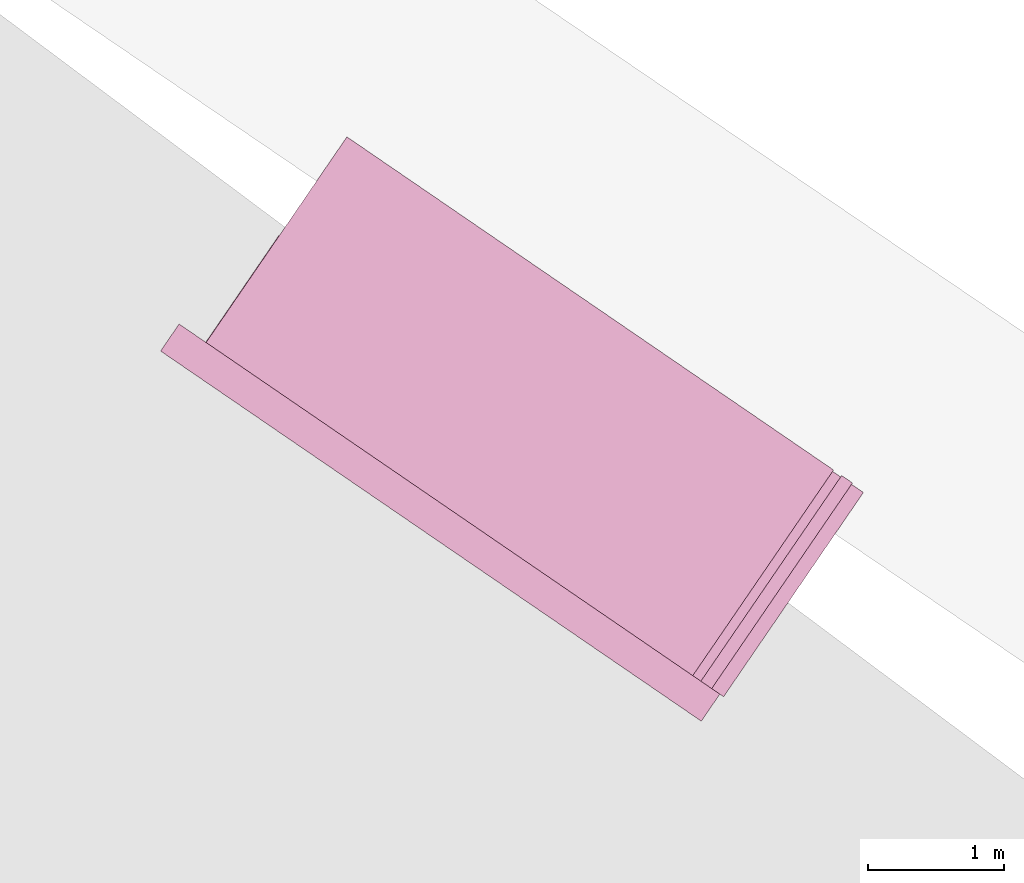
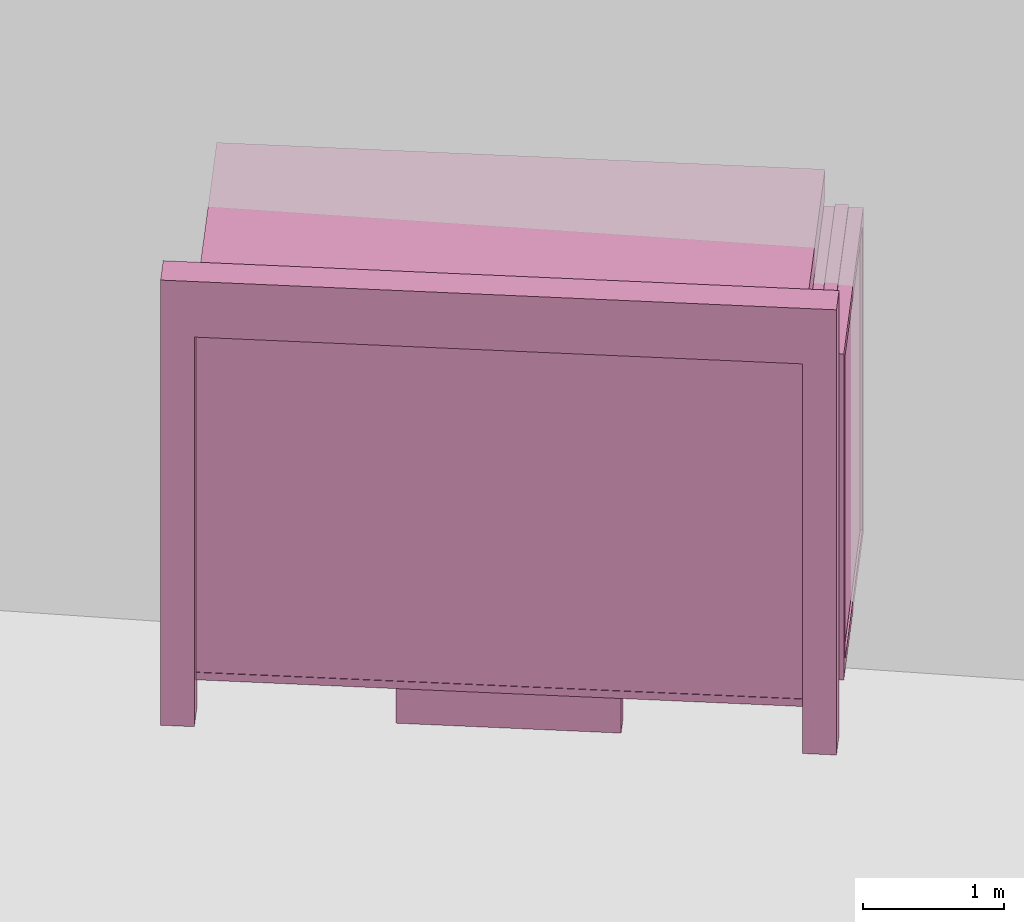
# One storey, part 56 of 200: 1 furnishing.
"""IFC4 building model written with IfcOpenShell, lengths in metres."""

import ifcopenshell
import ifcopenshell.guid

model = None  # the IFC model being written
_history = None  # IfcOwnerHistory: only IFC2X3 demands one
_inside = {}  # id of a spatial element -> (the spatial element, [elements in it])
_under = {}  # id of a project, library or spatial element -> (it, [spatial elements below it])
_declared = {}  # id of a project -> (the project, [libraries it declares])
_typed = {}  # id of a type object -> (the type object, [elements of that type])
_made_of = {}  # id of a material, layer set ... -> (it, [elements and type objects made of it])


def new_model(schema):
    """Start an empty IFC model of exactly this schema.

    Asked for "IFC4X3", IfcOpenShell would pick the latest addendum, in which some entities
    have other attributes; the version numbers below select the first issue.
    IFC2X3 requires an IfcOwnerHistory on every rooted entity: one is made here for all.
    """
    global model, _history
    if schema == "IFC4X3":
        model = ifcopenshell.file(schema_version=(4, 3, 0, 0))
    else:
        model = ifcopenshell.file(schema=schema)
    _inside.clear()
    _under.clear()
    _declared.clear()
    _typed.clear()
    _made_of.clear()
    _history = None
    if model.schema == "IFC2X3":
        org = make("IfcOrganization", Name="unknown")
        user = make(
            "IfcPersonAndOrganization",
            ThePerson=make("IfcPerson", FamilyName="unknown"),
            TheOrganization=org,
        )
        app = make(
            "IfcApplication",
            ApplicationDeveloper=org,
            Version="unknown",
            ApplicationFullName="unknown",
            ApplicationIdentifier="unknown",
        )
        _history = make(
            "IfcOwnerHistory",
            OwningUser=user,
            OwningApplication=app,
            ChangeAction="ADDED",
            CreationDate=0,
        )
    return model


def make(cls, **values):
    """One entity of the class cls with the attributes given. An attribute that is None is left unset."""
    return model.create_entity(
        cls, **{name: value for name, value in values.items() if value is not None}
    )


def rooted(cls, **values):
    """An entity with a GlobalId (a new one), such as an element, a storey or a relation."""
    return make(cls, GlobalId=ifcopenshell.guid.new(), OwnerHistory=_history, **values)


def si_unit(unit_type, name, prefix=None):
    """IfcSIUnit, for example si_unit("LENGTHUNIT", "METRE", prefix="MILLI")."""
    return make("IfcSIUnit", UnitType=unit_type, Prefix=prefix, Name=name)


def assignment(units):
    """IfcUnitAssignment: the units of a project."""
    return None if units is None else make("IfcUnitAssignment", Units=units)


def point(xyz):
    """IfcCartesianPoint."""
    return None if xyz is None else make("IfcCartesianPoint", Coordinates=xyz)


def direction(xyz):
    """IfcDirection."""
    return None if xyz is None else make("IfcDirection", DirectionRatios=xyz)


def frame(location, z_axis=None, x_axis=None):
    """IfcAxis2Placement3D, a coordinate frame: its origin and axes. An axis left out is left unset."""
    return make(
        "IfcAxis2Placement3D",
        Location=point(location),
        Axis=direction(z_axis),
        RefDirection=direction(x_axis),
    )


def origin_with_axes():
    """The frame at (0, 0, 0) with the z axis (0, 0, 1) and the x axis (1, 0, 0) written out."""
    return frame((0.0, 0.0, 0.0), z_axis=(0.0, 0.0, 1.0), x_axis=(1.0, 0.0, 0.0))


def place(relative_to, where):
    """IfcLocalPlacement: puts the frame where relative to a parent placement (None: the world)."""
    return make(
        "IfcLocalPlacement", PlacementRelTo=relative_to, RelativePlacement=where
    )


def context(
    kind, dimensions, precision=None, world=None, true_north=None, identifier=None
):
    """IfcGeometricRepresentationContext, for example the 3D "Model" context."""
    return make(
        "IfcGeometricRepresentationContext",
        ContextIdentifier=identifier,
        ContextType=kind,
        CoordinateSpaceDimension=dimensions,
        Precision=precision,
        WorldCoordinateSystem=world,
        TrueNorth=true_north,
    )


def subcontext(parent, identifier, kind, view, scale=None):
    """IfcGeometricRepresentationSubContext, for example "Body" below "Model"."""
    return make(
        "IfcGeometricRepresentationSubContext",
        ContextIdentifier=identifier,
        ContextType=kind,
        ParentContext=parent,
        TargetScale=scale,
        TargetView=view,
    )


def project(units=None, contexts=None):
    """IfcProject with its units and contexts."""
    return rooted(
        "IfcProject",
        Name="project",
        RepresentationContexts=contexts,
        UnitsInContext=assignment(units),
    )


def spatial(cls, under=None, at=None, **own):
    """A site, building, storey or space (cls), placed at a placement, below another one or the project."""
    s = rooted(cls, ObjectPlacement=at, **own)
    if under is not None:
        _under.setdefault(under.id(), (under, []))[1].append(s)
    return s


def point_list(points):
    """IfcCartesianPointList2D or 3D."""
    cls = (
        "IfcCartesianPointList2D" if len(points[0]) == 2 else "IfcCartesianPointList3D"
    )
    return make(cls, CoordList=points)


def triangles(points, corners, closed=None, point_numbers=None):
    """IfcTriangulatedFaceSet: each triangle names its three corners, points numbered from 1."""
    return make(
        "IfcTriangulatedFaceSet",
        Coordinates=point_list(points),
        Closed=closed,
        CoordIndex=corners,
        PnIndex=point_numbers,
    )


def shape(context_of_items, identifier, shape_type, items):
    """IfcShapeRepresentation: the items that make up one representation, for example the "Body"."""
    return make(
        "IfcShapeRepresentation",
        ContextOfItems=context_of_items,
        RepresentationIdentifier=identifier,
        RepresentationType=shape_type,
        Items=items,
    )


def material(Name=None, Category=None):
    """IfcMaterial."""
    return make("IfcMaterial", Name=Name, Category=Category)


def made_of(thing, what):
    """Note that an element or type object is made of a material, layer set ...; save() writes the relation."""
    if what is not None:
        _made_of.setdefault(what.id(), (what, []))[1].append(thing)
    return thing


def element(
    cls,
    number,
    at=None,
    inside=None,
    cuts=None,
    type_object=None,
    material=None,
    context=None,
    identifier="Body",
    shape_type=None,
    held_by="IfcProductDefinitionShape",
    body=None,
    shapes=None,
    **own,
):
    """One element of the class cls, such as IfcWall. Its Tag is "e" and its number.

    at: its placement. inside: the storey or other place that contains it. cuts: it is an
    opening in that element (IfcRelVoidsElement). A single representation is given by context,
    identifier, shape_type and body (its items); several are given by shapes. held_by: the class
    of the entity that holds the representations. save() writes the other relations.
    """
    e = rooted(cls, Tag="e%d" % number, ObjectPlacement=at, **own)
    if body is not None:
        shapes = [shape(context, identifier, shape_type, body)]
    if shapes is not None:
        e.Representation = make(held_by, Representations=shapes)
    if inside is not None:
        _inside.setdefault(inside.id(), (inside, []))[1].append(e)
    if cuts is not None:
        rooted(
            "IfcRelVoidsElement", RelatingBuildingElement=cuts, RelatedOpeningElement=e
        )
    if type_object is not None:
        _typed.setdefault(type_object.id(), (type_object, []))[1].append(e)
    return made_of(e, material)


def aggregate(whole, parts):
    """IfcRelAggregates: a whole, such as a stair, and the parts it consists of."""
    return rooted("IfcRelAggregates", RelatingObject=whole, RelatedObjects=parts)


def save(model, path):
    """Write the relations noted so far, then the file.

    IfcRelAggregates (storeys below a building ...), IfcRelContainedInSpatialStructure (elements
    in a storey), IfcRelDefinesByType, IfcRelAssociatesMaterial and IfcRelDeclares: one each for
    every whole, place, type object, material and project.
    """
    for whole, parts in _under.values():
        aggregate(whole, parts)
    for where, things in _inside.values():
        rooted(
            "IfcRelContainedInSpatialStructure",
            RelatedElements=things,
            RelatingStructure=where,
        )
    for kind, things in _typed.values():
        rooted("IfcRelDefinesByType", RelatedObjects=things, RelatingType=kind)
    for what, things in _made_of.values():
        rooted("IfcRelAssociatesMaterial", RelatedObjects=things, RelatingMaterial=what)
    for by, libraries in _declared.values():
        rooted("IfcRelDeclares", RelatingContext=by, RelatedDefinitions=libraries)
    model.write(path)


model = new_model("IFC4")

# Units and contexts
model_context = context("Model", 3, precision=1e-05, world=origin_with_axes())
body_context = subcontext(model_context, "Body", "Model", "MODEL_VIEW")
ifc_project = project(units=[si_unit("VOLUMEUNIT", "CUBIC_METRE"), si_unit("LENGTHUNIT", "METRE"), si_unit("AREAUNIT", "SQUARE_METRE")], contexts=[model_context])

# Site, building, storey
site_placement = place(None, origin_with_axes())
site = spatial("IfcSite", under=ifc_project, at=site_placement)
building_placement = place(site_placement, origin_with_axes())
building = spatial("IfcBuilding", under=site, at=building_placement, Name="Building")
storey_placement = place(building_placement, origin_with_axes())
storey = spatial("IfcBuildingStorey", under=building, at=storey_placement, Name="Ground")

# Furnishing
ifc_material = material(Name="busStop")
furnishing_placement = place(storey_placement, origin_with_axes())
element("IfcFurnishingElement", 1, at=furnishing_placement, inside=storey, material=ifc_material, Name="cw_instances_busStop_33", context=body_context, shape_type="Tessellation", body=[
    triangles([(611.8677199834349, -420.66740595626703, 3.3826375611235573), (607.1156591688147, -419.92843405890915, 3.3826375611235573), (610.6958969682652, -422.3792463698287, 3.3826375611235573), (608.2874821561248, -418.2165933731178, 3.3826375611235573), (611.8677200378974, -420.6674058767062, 3.6236783199298275), (607.1156592232771, -419.9284339793483, 3.6236783199298275), (608.2874822105873, -418.2165932935569, 3.6236783199298275), (610.6958970227276, -422.3792462902678, 3.6236783199298275), (611.8677199834349, -420.66740595626703, 3.3826375611235573), (608.2874822105873, -418.2165932935569, 3.6236783199298275), (608.2874821561248, -418.2165933731178, 3.3826375611235573), (611.8677200378974, -420.6674058767062, 3.6236783199298275), (608.2874821561248, -418.2165933731178, 3.3826375611235573), (607.1156592232771, -419.9284339793483, 3.6236783199298275), (607.1156591688147, -419.92843405890915, 3.3826375611235573), (608.2874822105873, -418.2165932935569, 3.6236783199298275), (607.1156591688147, -419.92843405890915, 3.3826375611235573), (610.6958970227276, -422.3792462902678, 3.6236783199298275), (610.6958969682652, -422.3792463698287, 3.3826375611235573), (607.1156592232771, -419.9284339793483, 3.6236783199298275), (610.6958969682652, -422.3792463698287, 3.3826375611235573), (611.8677200378974, -420.6674058767062, 3.6236783199298275), (611.8677199834349, -420.66740595626703, 3.3826375611235573), (610.6958970227276, -422.3792462902678, 3.6236783199298275), (610.8320534129081, -422.180343876926, 3.864718677001767), (610.8947994989808, -422.5154022756171, 3.864718677001767), (610.6958972315006, -422.37924598528457, 3.864718677001767), (611.0309556803883, -422.3165001672585, 3.864718677001767), (610.8320534129081, -422.180343876926, 3.6236783199298275), (611.0309556803883, -422.3165001672585, 3.864718677001767), (610.8320534129081, -422.180343876926, 3.864718677001767), (611.0309556803883, -422.3165001672585, 3.6236783199298275), (607.0529136363612, -419.59337522129414, 3.6236783199298275), (606.9167573460286, -419.7922774887744, 3.864718677001767), (606.9167573460286, -419.7922774887744, 3.6236783199298275), (607.0529136363612, -419.59337522129414, 3.864718677001767), (607.115659441127, -419.92843366110486, 3.6236783199298275), (606.9167573460286, -419.7922774887744, 3.864718677001767), (607.115659441127, -419.92843366110486, 3.864718677001767), (606.9167573460286, -419.7922774887744, 3.6236783199298275), (610.8947993991329, -422.5154024214786, 3.6236783199298275), (611.0309556803883, -422.3165001672585, 3.864718677001767), (611.0309556803883, -422.3165001672585, 3.6236783199298275), (610.8947994989808, -422.5154022756171, 3.864718677001767), (607.2518156225347, -419.7295315527463, 3.864718677001767), (607.115659441127, -419.92843366110486, 3.864718677001767), (607.2518156225347, -419.7295315527463, 3.6236783199298275), (607.2518156225347, -419.7295315527463, 3.864718677001767), (610.8947993991329, -422.5154024214786, 3.6236783199298275), (610.6958972315006, -422.37924598528457, 3.864718677001767), (610.8947994989808, -422.5154022756171, 3.864718677001767), (610.6958972315006, -422.37924598528457, 3.6236783199298275), (607.0529136363612, -419.59337522129414, 3.864718677001767), (606.9167573460286, -419.7922774887744, 3.864718677001767), (607.0529136363612, -419.59337522129414, 3.6236783199298275), (607.0529136363612, -419.59337522129414, 3.864718677001767), (610.8947989089705, -422.51540313752633, 9.480930192426488e-07), (611.0309550359157, -422.31650110872863, 8.998848996201414e-07), (610.6958966414903, -422.3792468471938, 9.480930192426488e-07), (610.8947989089705, -422.51540313752633, 9.480930192426488e-07), (610.6958972315006, -422.37924598528457, 3.6236783199298275), (610.8320528682833, -422.18034467253455, 8.998848996201414e-07), (610.8320534129081, -422.180343876926, 3.6236783199298275), (610.6958966414903, -422.3792468471938, 9.480930192426488e-07), (611.0309550359157, -422.31650110872863, 8.998848996201414e-07), (610.8320528682833, -422.18034467253455, 8.998848996201414e-07), (607.0529142425249, -419.593377038347, 8.998848996201414e-07), (606.9167567560185, -419.79227835068366, 9.480930192426488e-07), (607.2518163508835, -419.7295332197545, 8.998848996201414e-07), (607.0529142425249, -419.593377038347, 8.998848996201414e-07), (607.2518156225347, -419.7295315527463, 3.6236783199298275), (607.1156601240905, -419.9284353944138, 9.480930192426488e-07), (607.115659441127, -419.92843366110486, 3.6236783199298275), (607.2518163508835, -419.7295332197545, 8.998848996201414e-07), (606.9167567560185, -419.79227835068366, 9.480930192426488e-07), (607.1156601240905, -419.9284353944138, 9.480930192426488e-07), (607.7894438424429, -418.9445874695847, 0.3459945917589383), (607.1984381700588, -419.807950947275, 3.3826375611235573), (607.1984376798965, -419.8079516633227, 0.34599476852204364), (607.7894442872198, -418.9445868198377, 3.3826375611235573), (607.2116978089616, -419.8170287342164, 0.34599476852204364), (607.8027044162849, -418.9536638907314, 3.3826375611235573), (607.802703971508, -418.95366454047837, 0.3459945917589383), (607.211698299124, -419.8170280181687, 3.3826375611235573), (607.802703971508, -418.95366454047837, 0.3459945917589383), (607.7894442872198, -418.9445868198377, 3.3826375611235573), (607.7894438424429, -418.9445874695847, 0.3459945917589383), (607.8027044162849, -418.9536638907314, 3.3826375611235573), (607.2150129241038, -419.81929805867156, 0.313856054245785), (607.7861288591912, -418.9423182938349, 0.3138558614133065), (607.1951227238761, -419.8056824477925, 0.313856054245785), (607.806019059419, -418.95593390471396, 0.3138558614133065), (607.2150129241038, -419.81929805867156, 0.37813349886767544), (607.7861288682683, -418.94231828057474, 0.37813330603519696), (607.806019068496, -418.9559338914538, 0.37813330603519696), (607.1951227238761, -419.8056824477925, 0.37813349886767544), (607.2150129241038, -419.81929805867156, 0.313856054245785), (607.806019068496, -418.9559338914538, 0.37813330603519696), (607.806019059419, -418.95593390471396, 0.3138558614133065), (607.2150129241038, -419.81929805867156, 0.37813349886767544), (607.7861288591912, -418.9423182938349, 0.3138558614133065), (607.1951227238761, -419.8056824477925, 0.37813349886767544), (607.1951227238761, -419.8056824477925, 0.313856054245785), (607.7861288682683, -418.94231828057474, 0.37813330603519696), (607.7861288682683, -418.94231828057474, 0.37813330603519696), (607.806019059419, -418.95593390471396, 0.3138558614133065), (607.806019068496, -418.9559338914538, 0.37813330603519696), (607.7861288591912, -418.9423182938349, 0.3138558614133065), (607.8154393463792, -418.93556688120964, 0.37813330603519696), (607.776710081837, -418.96268615598535, 0.37813330603519696), (607.8017084690015, -418.9261675648999, 0.37813330603519696), (607.7904409592147, -418.9720854722951, 0.37813330603519696), (607.815439201146, -418.9355670933719, 1.446243588675227e-07), (607.8017084690015, -418.9261675648999, 0.37813330603519696), (607.8017083237681, -418.9261677770622, 1.446243588675227e-07), (607.8154393463792, -418.93556688120964, 0.37813330603519696), (607.8017083237681, -418.9261677770622, 1.446243588675227e-07), (607.776710081837, -418.96268615598535, 0.37813330603519696), (607.7767100182974, -418.96268624880634, 1.6069373207502523e-07), (607.8017084690015, -418.9261675648999, 0.37813330603519696), (607.7767100182974, -418.96268624880634, 1.6069373207502523e-07), (607.7904409592147, -418.9720854722951, 0.37813330603519696), (607.7904408956751, -418.9720855651161, 1.6069373207502523e-07), (607.776710081837, -418.96268615598535, 0.37813330603519696), (607.7904408956751, -418.9720855651161, 1.6069373207502523e-07), (607.8154393463792, -418.93556688120964, 0.37813330603519696), (607.815439201146, -418.9355670933719, 1.446243588675227e-07), (607.7904409592147, -418.9720854722951, 0.37813330603519696), (609.7910825041278, -421.38798053360796, 1.1248564780513874), (608.3783969625986, -420.606885268444, 1.1248565744676267), (608.4650685439145, -420.48027213872564, 1.1248564780513874), (609.7044110317369, -421.5145935042046, 1.1248565744676267), (608.4650684349896, -420.48027229784736, 4.981505694325782e-07), (609.7910825041278, -421.38798053360796, 0.964162810253855), (608.4650685439145, -420.48027213872564, 0.964162810253855), (609.7910823135092, -421.3879808120709, 4.981505694325782e-07), (608.3783967447487, -420.6068855866874, 5.302893158475833e-07), (608.4650685439145, -420.48027213872564, 0.964162810253855), (608.3783969625986, -420.606885268444, 0.9641629066700942), (608.4650684349896, -420.48027229784736, 4.981505694325782e-07), (609.7044108138869, -421.514593822448, 5.302893158475833e-07), (608.3783969625986, -420.606885268444, 0.9641629066700942), (609.7044110317369, -421.5145935042046, 0.9641629066700942), (608.3783967447487, -420.6068855866874, 5.302893158475833e-07), (609.7910823135092, -421.3879808120709, 4.981505694325782e-07), (609.7044110317369, -421.5145935042046, 0.9641629066700942), (609.7910825041278, -421.38798053360796, 0.964162810253855), (609.7044108138869, -421.514593822448, 5.302893158475833e-07), (608.8281517064374, -419.94986649875597, 1.124856381635148), (610.154165712036, -420.85757482733754, 0.9641627138376155), (610.1541657301902, -420.85757480081725, 1.124856381635148), (608.8281516973603, -419.94986651201606, 0.9641627138376155), (608.3783969625986, -420.606885268444, 1.1248565744676267), (608.4650685439145, -420.48027213872564, 1.1248564780513874), (609.7044110317369, -421.5145935042046, 1.1248565744676267), (608.3783969625986, -420.606885268444, 1.1248565744676267), (609.7910825041278, -421.38798053360796, 1.1248564780513874), (609.7044110317369, -421.5145935042046, 1.1248565744676267), (610.1541657301902, -420.85757480081725, 1.124856381635148), (608.8281517064374, -419.94986649875597, 1.124856381635148), (610.154165712036, -420.85757482733754, 0.9641627138376155), (610.1541657301902, -420.85757480081725, 1.124856381635148), (608.8281517064374, -419.94986649875597, 1.124856381635148), (608.8281516973603, -419.94986651201606, 0.9641627138376155), (610.8982631142915, -422.3308895919302, 0.34599476852204364), (607.1033188695504, -419.7331011348145, 3.503157940526693), (607.1033183340027, -419.7331019171629, 0.34599476852204364), (610.8982634955289, -422.33088903500425, 3.503157940526693), (607.0942412540319, -419.74636205948815, 0.34599476852204364), (610.8891864246352, -422.34414916406934, 3.503157940526693), (610.8891860433978, -422.34414972099535, 0.34599476852204364), (607.0942417986566, -419.74636126387963, 3.503157940526693), (611.100084547328, -422.2469802879865, 0.5810001600002933), (612.0199009878497, -420.90327758252494, 3.2193552137185355), (612.0199006610749, -420.90327805989006, 0.5809998707515756), (611.1000848922571, -422.2469797841011, 3.2193552137185355), (611.0588821965684, -422.3356182128317, 0.4845839046859049), (612.03316079014, -420.91235513078374, 0.5809998707515756), (612.0876244752158, -420.83279521871566, 0.48458358329844076), (611.1133446763931, -422.2560573588802, 0.5810001600002933), (612.0331611169149, -420.9123546534186, 3.2193552137185355), (612.0876237056646, -420.83279364034536, 3.3157713565473115), (611.1133450213222, -422.25605685499477, 3.2193552137185355), (611.0588825687288, -422.3356176691659, 3.3157713565473115), (611.1133446763931, -422.2560573588802, 0.5810001600002933), (612.0199006610749, -420.90327805989006, 0.5809998707515756), (612.03316079014, -420.91235513078374, 0.5809998707515756), (611.100084547328, -422.2469802879865, 0.5810001600002933), (612.03316079014, -420.91235513078374, 0.5809998707515756), (612.0199009878497, -420.90327758252494, 3.2193552137185355), (612.0331611169149, -420.9123546534186, 3.2193552137185355), (612.0199006610749, -420.90327805989006, 0.5809998707515756), (612.0331611169149, -420.9123546534186, 3.2193552137185355), (611.1000848922571, -422.2469797841011, 3.2193552137185355), (611.1133450213222, -422.25605685499477, 3.2193552137185355), (612.0199009878497, -420.90327758252494, 3.2193552137185355), (611.1133450213222, -422.25605685499477, 3.2193552137185355), (611.100084547328, -422.2469802879865, 0.5810001600002933), (611.1133446763931, -422.2560573588802, 0.5810001600002933), (611.1000848922571, -422.2469797841011, 3.2193552137185355), (611.8328672258035, -420.6584029826849, 3.3157713565473115), (611.0588825687288, -422.3356176691659, 3.3157713565473115), (610.8041262522552, -422.1612267728229, 3.3157713565473115), (612.0876237056646, -420.83279364034536, 3.3157713565473115), (611.8328667356412, -420.6584036987326, 0.48458358329844076), (612.0876237056646, -420.83279364034536, 3.3157713565473115), (611.8328672258035, -420.6584029826849, 3.3157713565473115), (612.0876244752158, -420.83279521871566, 0.48458358329844076), (611.0588821965684, -422.3356182128317, 0.4845839046859049), (610.8041262522552, -422.1612267728229, 3.3157713565473115), (611.0588825687288, -422.3356176691659, 3.3157713565473115), (610.8041258165554, -422.1612274093097, 0.4845839046859049), (610.871848407291, -422.0907436527721, 0.5810001600002933), (611.791664766119, -420.7470410666519, 3.2193552137185355), (610.871848861145, -422.09074298976503, 3.2193552137185355), (611.7916644393441, -420.747041544017, 0.5809998707515756), (610.8041258165554, -422.1612274093097, 0.4845839046859049), (611.778404310279, -420.73796447312327, 0.5809998707515756), (610.8585882782259, -422.08166658187844, 0.5810001600002933), (611.8328667356412, -420.6584036987326, 0.48458358329844076), (611.7784046370539, -420.73796399575815, 3.2193552137185355), (611.8328672258035, -420.6584029826849, 3.3157713565473115), (610.8585887320799, -422.08166591887135, 3.2193552137185355), (610.8041262522552, -422.1612267728229, 3.3157713565473115), (610.8585882782259, -422.08166658187844, 0.5810001600002933), (611.7916644393441, -420.747041544017, 0.5809998707515756), (610.871848407291, -422.0907436527721, 0.5810001600002933), (611.778404310279, -420.73796447312327, 0.5809998707515756), (611.778404310279, -420.73796447312327, 0.5809998707515756), (611.791664766119, -420.7470410666519, 3.2193552137185355), (611.7916644393441, -420.747041544017, 0.5809998707515756), (611.7784046370539, -420.73796399575815, 3.2193552137185355), (611.7784046370539, -420.73796399575815, 3.2193552137185355), (610.871848861145, -422.09074298976503, 3.2193552137185355), (611.791664766119, -420.7470410666519, 3.2193552137185355), (610.8585887320799, -422.08166591887135, 3.2193552137185355), (610.8585887320799, -422.08166591887135, 3.2193552137185355), (610.871848407291, -422.0907436527721, 0.5810001600002933), (610.871848861145, -422.09074298976503, 3.2193552137185355), (610.8585882782259, -422.08166658187844, 0.5810001600002933), (612.0069500855352, -420.76271434286684, 3.3287619342644956), (610.8917239416029, -422.22119112765455, 3.3287619342644956), (611.9273905708579, -420.70825277982726, 3.3287619342644956), (610.9712847159936, -422.27565355301675, 3.3287619342644956), (612.006951123133, -420.76271587104037, 0.0), (611.9273905708579, -420.70825277982726, 3.3287619342644956), (611.9273901896206, -420.7082533367532, 0.0), (612.0069500855352, -420.76271434286684, 3.3287619342644956), (611.9273901896206, -420.7082533367532, 0.0), (610.8917239416029, -422.22119112765455, 3.3287619342644956), (610.8917235149802, -422.22119175088125, 5.142199426400808e-07), (611.9273905708579, -420.70825277982726, 3.3287619342644956), (610.8917235149802, -422.22119175088125, 5.142199426400808e-07), (610.9712847159936, -422.27565355301675, 3.3287619342644956), (610.9712842893708, -422.27565417624345, 5.142199426400808e-07), (610.8917239416029, -422.22119112765455, 3.3287619342644956), (610.9712842893708, -422.27565417624345, 5.142199426400808e-07), (612.0069500855352, -420.76271434286684, 3.3287619342644956), (612.006951123133, -420.76271587104037, 0.0), (610.9712847159936, -422.27565355301675, 3.3287619342644956), (610.9005323842842, -422.3275745563489, 0.313856054245785), (607.1740773741371, -419.80588150561005, 0.313856054245785), (610.8869167189426, -422.3474648361375, 0.313856054245785), (607.1876929759392, -419.7859913186424, 0.313856054245785), (610.9005323842842, -422.3275745563489, 0.37813349886767544), (607.1740773741371, -419.80588150561005, 0.37813349886767544), (607.1876929759392, -419.7859913186424, 0.37813349886767544), (610.8869167189426, -422.3474648361375, 0.37813349886767544), (610.9005323842842, -422.3275745563489, 0.313856054245785), (607.1876929759392, -419.7859913186424, 0.37813349886767544), (607.1876929759392, -419.7859913186424, 0.313856054245785), (610.9005323842842, -422.3275745563489, 0.37813349886767544), (607.1740773741371, -419.80588150561005, 0.313856054245785), (610.8869167189426, -422.3474648361375, 0.37813349886767544), (610.8869167189426, -422.3474648361375, 0.313856054245785), (607.1740773741371, -419.80588150561005, 0.37813349886767544), (609.5723233546437, -421.4230713512028, 1.5290613779533648), (608.5115123366004, -420.6969043875373, 2.8146110577904615), (609.5723235724936, -421.42307103295934, 2.8146110577904615), (608.5115121187505, -420.6969047057807, 1.5290613779533648), (609.5534329143045, -421.3937711971708, 1.5612002850621018), (608.5456624830055, -420.7039125848027, 2.7824723435142027), (608.5456621653076, -420.70391304890774, 1.5612002850621018), (609.5534330232294, -421.39377103804907, 2.7824723435142027), (609.5723233546437, -421.4230713512028, 1.5290613779533648), (608.5282190472157, -420.67249859170227, 1.5290613779533648), (608.5115121187505, -420.6969047057807, 1.5290613779533648), (609.5890301741839, -421.39866539624603, 1.5290613779533648), (608.5115121187505, -420.6969047057807, 1.5290613779533648), (608.5282191470635, -420.6724984458407, 2.8146110577904615), (608.5115123366004, -420.6969043875373, 2.8146110577904615), (608.5282190472157, -420.67249859170227, 1.5290613779533648), (608.5115123366004, -420.6969043875373, 2.8146110577904615), (609.5890303920338, -421.39866507800264, 2.8146110577904615), (609.5723235724936, -421.42307103295934, 2.8146110577904615), (608.5282191470635, -420.6724984458407, 2.8146110577904615), (609.5723235724936, -421.42307103295934, 2.8146110577904615), (609.5890301741839, -421.39866539624603, 1.5290613779533648), (609.5723233546437, -421.4230713512028, 1.5290613779533648), (609.5890303920338, -421.39866507800264, 2.8146110577904615), (608.2018315591921, -420.48491639256684, 1.5290613779533648), (607.5388247990683, -420.0310617030785, 2.8146110577904615), (608.2018318064062, -420.48491586073925, 2.8146110577904615), (607.5388245812184, -420.03106202132193, 1.5290613779533648), (608.1829408905867, -420.45561631596286, 1.5612002850621018), (607.5729747423055, -420.03807011179526, 2.7824723435142027), (607.5729745789181, -420.0380703504778, 1.5612002850621018), (608.1829412082845, -420.45561585185783, 2.7824723435142027), (608.2018315591921, -420.48491639256684, 1.5290613779533648), (607.5555313916815, -420.0066560796253, 1.5290613779533648), (607.5388245812184, -420.03106202132193, 1.5290613779533648), (608.2185384876573, -420.46051027848836, 1.5290613779533648), (607.5388245812184, -420.03106202132193, 1.5290613779533648), (607.5555316095314, -420.00665576138186, 2.8146110577904615), (607.5388247990683, -420.0310617030785, 2.8146110577904615), (607.5555313916815, -420.0066560796253, 1.5290613779533648), (607.5388247990683, -420.0310617030785, 2.8146110577904615), (608.2185386168693, -420.46050991904264, 2.8146110577904615), (608.2018318064062, -420.48491586073925, 2.8146110577904615), (607.5555316095314, -420.00665576138186, 2.8146110577904615), (608.2018318064062, -420.48491586073925, 2.8146110577904615), (608.2185384876573, -420.46051027848836, 1.5290613779533648), (608.2018315591921, -420.48491639256684, 1.5290613779533648), (608.2185386168693, -420.46050991904264, 2.8146110577904615), (609.5890301741839, -421.39866539624603, 1.5290613779533648), (608.5547392906639, -420.69065284028176, 1.5612002850621018), (608.5282190472157, -420.67249859170227, 1.5290613779533648), (609.5625098762732, -421.3805112272274, 1.5612002850621018), (608.5547394449742, -420.69065261485935, 2.7824723435142027), (608.5282191470635, -420.6724984458407, 2.8146110577904615), (609.5625100941231, -421.380510908984, 2.7824723435142027), (609.5890303920338, -421.39866507800264, 2.8146110577904615), (608.2185384876573, -420.46051027848836, 1.5290613779533648), (607.5820516498118, -420.0248102214127, 1.5612002850621018), (607.5555313916815, -420.0066560796253, 1.5290613779533648), (608.1920180704054, -420.442356027776, 1.5612002850621018), (607.5820518676617, -420.0248099031693, 2.7824723435142027), (607.5555316095314, -420.00665576138186, 2.8146110577904615), (608.1920182791782, -420.44235572279274, 2.7824723435142027), (608.2185386168693, -420.46050991904264, 2.8146110577904615), (609.5625098762732, -421.3805112272274, 1.5612002850621018), (608.5456621653076, -420.70391304890774, 1.5612002850621018), (608.5547392906639, -420.69065284028176, 1.5612002850621018), (609.5534329143045, -421.3937711971708, 1.5612002850621018), (608.5547392906639, -420.69065284028176, 1.5612002850621018), (608.5456624830055, -420.7039125848027, 2.7824723435142027), (608.5547394449742, -420.69065261485935, 2.7824723435142027), (608.5456621653076, -420.70391304890774, 1.5612002850621018), (608.5547394449742, -420.69065261485935, 2.7824723435142027), (609.5534330232294, -421.39377103804907, 2.7824723435142027), (609.5625100941231, -421.380510908984, 2.7824723435142027), (608.5456624830055, -420.7039125848027, 2.7824723435142027), (609.5625100941231, -421.380510908984, 2.7824723435142027), (609.5534329143045, -421.3937711971708, 1.5612002850621018), (609.5625098762732, -421.3805112272274, 1.5612002850621018), (609.5534330232294, -421.39377103804907, 2.7824723435142027), (608.1920180704054, -420.442356027776, 1.5612002850621018), (607.5729745789181, -420.0380703504778, 1.5612002850621018), (607.5820516498118, -420.0248102214127, 1.5612002850621018), (608.1829408905867, -420.45561631596286, 1.5612002850621018), (607.5820516498118, -420.0248102214127, 1.5612002850621018), (607.5729747423055, -420.03807011179526, 2.7824723435142027), (607.5820518676617, -420.0248099031693, 2.7824723435142027), (607.5729745789181, -420.0380703504778, 1.5612002850621018), (607.5820518676617, -420.0248099031693, 2.7824723435142027), (608.1829412082845, -420.45561585185783, 2.7824723435142027), (608.1920182791782, -420.44235572279274, 2.7824723435142027), (607.5729747423055, -420.03807011179526, 2.7824723435142027), (608.1920182791782, -420.44235572279274, 2.7824723435142027), (608.1829408905867, -420.45561631596286, 1.5612002850621018), (608.1920180704054, -420.442356027776, 1.5612002850621018), (608.1829412082845, -420.45561585185783, 2.7824723435142027)], [[1, 3, 2], [2, 4, 1], [5, 7, 6], [6, 8, 5], [9, 11, 10], [10, 12, 9], [13, 15, 14], [14, 16, 13], [17, 19, 18], [18, 20, 17], [21, 23, 22], [22, 24, 21], [25, 27, 26], [26, 28, 25], [29, 31, 30], [30, 32, 29], [33, 35, 34], [34, 36, 33], [37, 39, 38], [38, 40, 37], [41, 43, 42], [42, 44, 41], [45, 46, 27], [27, 25, 45], [47, 48, 31], [31, 29, 47], [49, 51, 50], [50, 52, 49], [52, 50, 39], [39, 37, 52], [53, 54, 46], [46, 45, 53], [55, 56, 48], [48, 47, 55], [43, 41, 57], [57, 58, 43], [49, 52, 59], [59, 60, 49], [61, 63, 62], [62, 64, 61], [29, 32, 65], [65, 66, 29], [35, 33, 67], [67, 68, 35], [55, 47, 69], [69, 70, 55], [71, 73, 72], [72, 74, 71], [37, 40, 75], [75, 76, 37], [77, 79, 78], [78, 80, 77], [81, 83, 82], [82, 84, 81], [85, 87, 86], [86, 88, 85], [89, 91, 90], [90, 92, 89], [93, 95, 94], [94, 96, 93], [97, 99, 98], [98, 100, 97], [101, 103, 102], [102, 104, 101], [105, 107, 106], [106, 108, 105], [109, 111, 110], [110, 112, 109], [113, 115, 114], [114, 116, 113], [117, 119, 118], [118, 120, 117], [121, 123, 122], [122, 124, 121], [125, 127, 126], [126, 128, 125], [129, 131, 130], [130, 132, 129], [133, 135, 134], [134, 136, 133], [137, 139, 138], [138, 140, 137], [141, 143, 142], [142, 144, 141], [145, 147, 146], [146, 148, 145], [149, 151, 150], [150, 152, 149], [153, 154, 138], [138, 139, 153], [155, 156, 142], [142, 143, 155], [157, 158, 146], [146, 147, 157], [131, 129, 159], [159, 160, 131], [157, 147, 161], [161, 162, 157], [138, 154, 163], [163, 164, 138], [165, 167, 166], [166, 168, 165], [169, 171, 170], [170, 172, 169], [173, 175, 174], [174, 176, 173], [177, 179, 178], [178, 180, 177], [179, 182, 181], [181, 178, 179], [182, 184, 183], [183, 181, 182], [184, 177, 180], [180, 183, 184], [185, 187, 186], [186, 188, 185], [189, 191, 190], [190, 192, 189], [193, 195, 194], [194, 196, 193], [197, 199, 198], [198, 200, 197], [201, 203, 202], [202, 204, 201], [205, 207, 206], [206, 208, 205], [209, 211, 210], [210, 212, 209], [213, 215, 214], [214, 216, 213], [217, 219, 218], [218, 220, 217], [220, 218, 221], [221, 222, 220], [222, 221, 223], [223, 224, 222], [224, 223, 219], [219, 217, 224], [225, 227, 226], [226, 228, 225], [229, 231, 230], [230, 232, 229], [233, 235, 234], [234, 236, 233], [237, 239, 238], [238, 240, 237], [241, 243, 242], [242, 244, 241], [245, 247, 246], [246, 248, 245], [249, 251, 250], [250, 252, 249], [253, 255, 254], [254, 256, 253], [257, 259, 258], [258, 260, 257], [261, 263, 262], [262, 264, 261], [265, 267, 266], [266, 268, 265], [269, 271, 270], [270, 272, 269], [273, 275, 274], [274, 276, 273], [277, 279, 278], [278, 280, 277], [281, 283, 282], [282, 284, 281], [285, 287, 286], [286, 288, 285], [289, 291, 290], [290, 292, 289], [293, 295, 294], [294, 296, 293], [297, 299, 298], [298, 300, 297], [301, 303, 302], [302, 304, 301], [305, 307, 306], [306, 308, 305], [309, 311, 310], [310, 312, 309], [313, 315, 314], [314, 316, 313], [317, 319, 318], [318, 320, 317], [321, 323, 322], [322, 324, 321], [325, 327, 326], [326, 328, 325], [327, 330, 329], [329, 326, 327], [330, 332, 331], [331, 329, 330], [332, 325, 328], [328, 331, 332], [333, 335, 334], [334, 336, 333], [335, 338, 337], [337, 334, 335], [338, 340, 339], [339, 337, 338], [340, 333, 336], [336, 339, 340], [341, 343, 342], [342, 344, 341], [345, 347, 346], [346, 348, 345], [349, 351, 350], [350, 352, 349], [353, 355, 354], [354, 356, 353], [357, 359, 358], [358, 360, 357], [361, 363, 362], [362, 364, 361], [365, 367, 366], [366, 368, 365], [369, 371, 370], [370, 372, 369]], closed=True),
])

save(model, "model.ifc")
